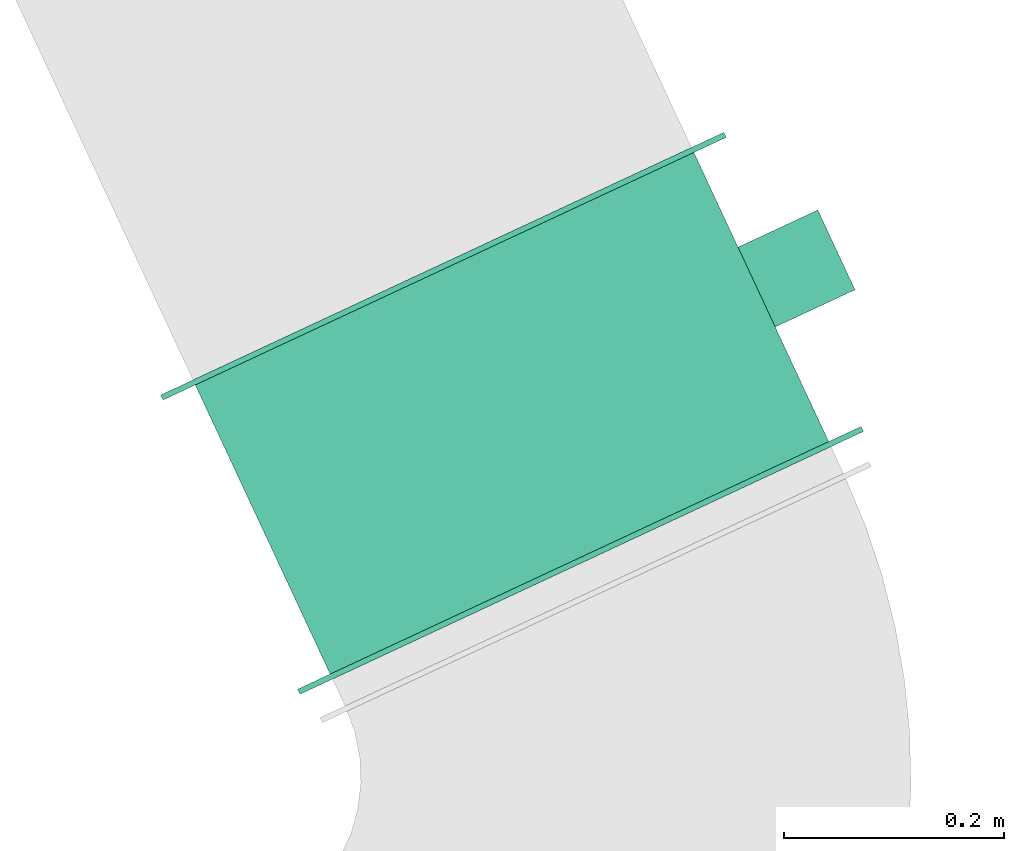
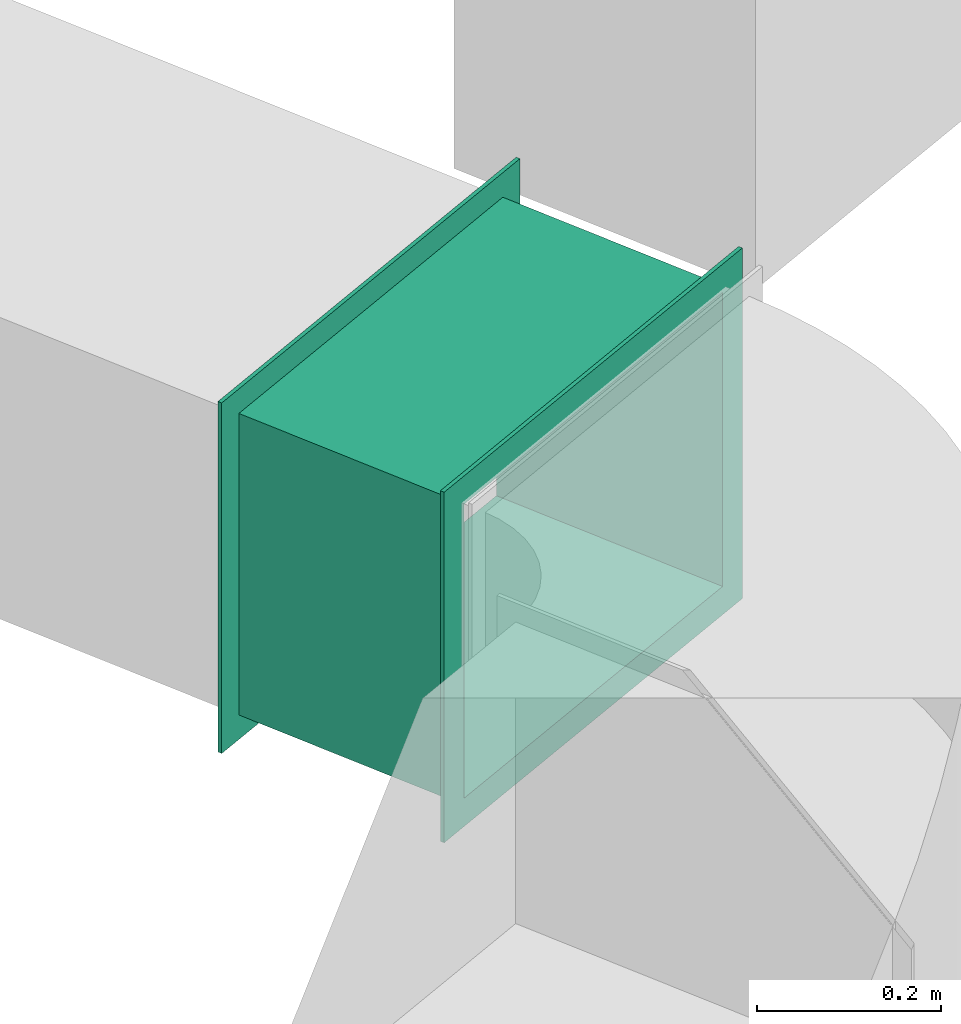
# One storey, part 2 of 2: 1 flow controller.
"""IFC2X3 building model written with IfcOpenShell, lengths in metres."""

from ifc_helpers import new_model, entity, si_unit, converted_unit, derived_unit, direction, frame, origin, place, context, subcontext, project, spatial, faceted_brep, source, transform, mapped, type_object, type_shapes, element, save


model = new_model("IFC2X3")

# Units and contexts
model_context = context("Model", 3, precision=1e-05, world=origin(), true_north=direction((6.12303176911189e-17, 1.0)))
body_context = subcontext(model_context, "Body", "Model", "MODEL_VIEW")
ifc_project = project(units=[si_unit("LENGTHUNIT", "METRE"), si_unit("AREAUNIT", "SQUARE_METRE"), si_unit("VOLUMEUNIT", "CUBIC_METRE"), converted_unit("PLANEANGLEUNIT", "DEGREE", entity("IfcRatioMeasure", 0.0174532925199433), si_unit("PLANEANGLEUNIT", "RADIAN"), dimensions=[0, 0, 0, 0, 0, 0, 0]), si_unit("MASSUNIT", "GRAM", prefix="KILO"), derived_unit("MASSDENSITYUNIT", [(si_unit("MASSUNIT", "GRAM", prefix="KILO"), 1), (si_unit("LENGTHUNIT", "METRE"), -3)]), si_unit("TIMEUNIT", "SECOND"), si_unit("FREQUENCYUNIT", "HERTZ"), si_unit("THERMODYNAMICTEMPERATUREUNIT", "DEGREE_CELSIUS"), derived_unit("THERMALTRANSMITTANCEUNIT", [(si_unit("MASSUNIT", "GRAM", prefix="KILO"), 1), (si_unit("THERMODYNAMICTEMPERATUREUNIT", "KELVIN"), -1), (si_unit("TIMEUNIT", "SECOND"), -3)]), derived_unit("VOLUMETRICFLOWRATEUNIT", [(si_unit("LENGTHUNIT", "METRE"), 3), (si_unit("TIMEUNIT", "SECOND"), -1)]), si_unit("ELECTRICCURRENTUNIT", "AMPERE"), si_unit("ELECTRICVOLTAGEUNIT", "VOLT"), si_unit("POWERUNIT", "WATT"), si_unit("FORCEUNIT", "NEWTON", prefix="KILO"), si_unit("ILLUMINANCEUNIT", "LUX"), si_unit("LUMINOUSFLUXUNIT", "LUMEN"), si_unit("LUMINOUSINTENSITYUNIT", "CANDELA"), derived_unit("USERDEFINED", [(si_unit("MASSUNIT", "GRAM", prefix="KILO"), -1), (si_unit("LENGTHUNIT", "METRE"), -2), (si_unit("TIMEUNIT", "SECOND"), 3), (si_unit("LUMINOUSFLUXUNIT", "LUMEN"), 1)]), derived_unit("LINEARVELOCITYUNIT", [(si_unit("LENGTHUNIT", "METRE"), 1), (si_unit("TIMEUNIT", "SECOND"), -1)]), si_unit("PRESSUREUNIT", "PASCAL"), derived_unit("USERDEFINED", [(si_unit("LENGTHUNIT", "METRE"), -2), (si_unit("MASSUNIT", "GRAM", prefix="KILO"), 1), (si_unit("TIMEUNIT", "SECOND"), -2)])], contexts=[model_context])

# Site, building, storey
site_placement = place(None, frame((-27.6339874998918, 64.4092442595216, 0.0), z_axis=(0.0, 0.0, 1.0), x_axis=(-0.422618261740703, 0.906307787036648, 0.0)))
site = spatial("IfcSite", under=ifc_project, at=site_placement, CompositionType="ELEMENT")
building_placement = place(site_placement, origin())
building = spatial("IfcBuilding", under=site, at=building_placement, CompositionType="ELEMENT")
storey_placement = place(building_placement, frame((0.0, 0.0, 2.56)))
storey = spatial("IfcBuildingStorey", under=building, at=storey_placement, CompositionType="ELEMENT", Elevation=2.56)

# Flow controller
damper_type = type_object("IfcDamperType", PredefinedType="FIREDAMPER")
shared_shape = source(origin(), body_context, "Body", "Brep", [
    faceted_brep([(-0.18, -0.245000000000001, 0.195), (-0.18, -0.245000000000001, -0.195), (-0.179999999999998, 0.245, -0.195), (-0.179999999999998, 0.245, 0.195), (-0.18, -0.2825, 0.232500000000001), (-0.179999999999998, 0.2825, 0.232500000000001), (-0.179999999999998, 0.2825, -0.232499999999999), (-0.18, -0.2825, -0.232499999999999), (0.12, -0.245000000000002, 0.195), (0.120000000000002, 0.244999999999999, 0.195), (0.120000000000002, 0.244999999999999, -0.195), (0.12, -0.245000000000001, -0.195), (0.12, -0.2825, 0.232500000000001), (0.12, -0.2825, -0.232499999999999), (0.120000000000002, 0.2825, -0.232499999999999), (0.120000000000002, 0.2825, 0.232500000000001), (-0.174999999999995, 0.25, 0.2), (-0.174999999999995, -0.250000000000001, 0.2), (0.115, -0.250000000000002, 0.2), (0.115, 0.249999999999999, 0.2), (-0.174999999999995, 0.25, -0.2), (0.115, 0.249999999999999, -0.2), (-0.174999999999995, -0.250000000000001, -0.2), (0.115, -0.250000000000002, -0.2), (-0.174999999999995, -0.2825, 0.232500000000001), (-0.174999999999995, -0.2825, -0.232499999999999), (-0.174999999999995, 0.2825, -0.232499999999999), (-0.174999999999995, 0.2825, 0.232500000000001), (0.115, -0.2825, 0.232500000000001), (0.115, 0.2825, 0.232500000000001), (0.115, 0.2825, -0.232499999999999), (0.115, -0.2825, -0.232499999999999)], [[[0, 1, 2, 3], [4, 5, 6, 7]], [[8, 9, 10, 11], [12, 13, 14, 15]], [[16, 17, 18, 19]], [[20, 16, 19, 21]], [[22, 20, 21, 23]], [[17, 22, 23, 18]], [[1, 0, 8, 11]], [[2, 1, 11, 10]], [[3, 2, 10, 9]], [[0, 3, 9, 8]], [[17, 16, 20, 22], [24, 25, 26, 27]], [[5, 4, 24, 27]], [[6, 5, 27, 26]], [[7, 6, 26, 25]], [[4, 7, 25, 24]], [[19, 18, 23, 21], [28, 29, 30, 31]], [[13, 12, 28, 31]], [[14, 13, 31, 30]], [[15, 14, 30, 29]], [[12, 15, 29, 28]]], outer=[[False, True], [False, True], [True], [True], [True], [True], [True], [True], [True], [True], [False, True], [True], [True], [True], [True], [False, True], [True], [True], [True], [True]]),
    faceted_brep([(-0.08, -0.33, -0.0399999999999995), (-0.08, -0.33, 0.0400000000000005), (-0.08, -0.25, 0.0400000000000004), (-0.08, -0.25, -0.0399999999999996), (0.0, -0.33, -0.0399999999999995), (0.0, -0.25, -0.0399999999999996), (0.0, -0.25, 0.0400000000000004), (0.0, -0.33, 0.0400000000000005)], [[[0, 1, 2, 3]], [[4, 5, 6, 7]], [[5, 4, 0, 3]], [[6, 5, 3, 2]], [[7, 6, 2, 1]], [[4, 7, 1, 0]]]),
])
type_shapes(damper_type, [shared_shape])
flow_controller_placement = place(storey_placement, frame((-21.2802222763718, 20.0416272162196, 1.56000218419231), z_axis=(0.0, 0.0, -1.0), x_axis=(-1.0, 0.0, 0.0)))
element("IfcFlowController", 1, at=flow_controller_placement, inside=storey, type_object=damper_type, context=body_context, shape_type="MappedRepresentation", body=[
    mapped(shared_shape, transform((0.0, 0.0, 0.0), scale=1.0)),
])

save(model, "model.ifc")
